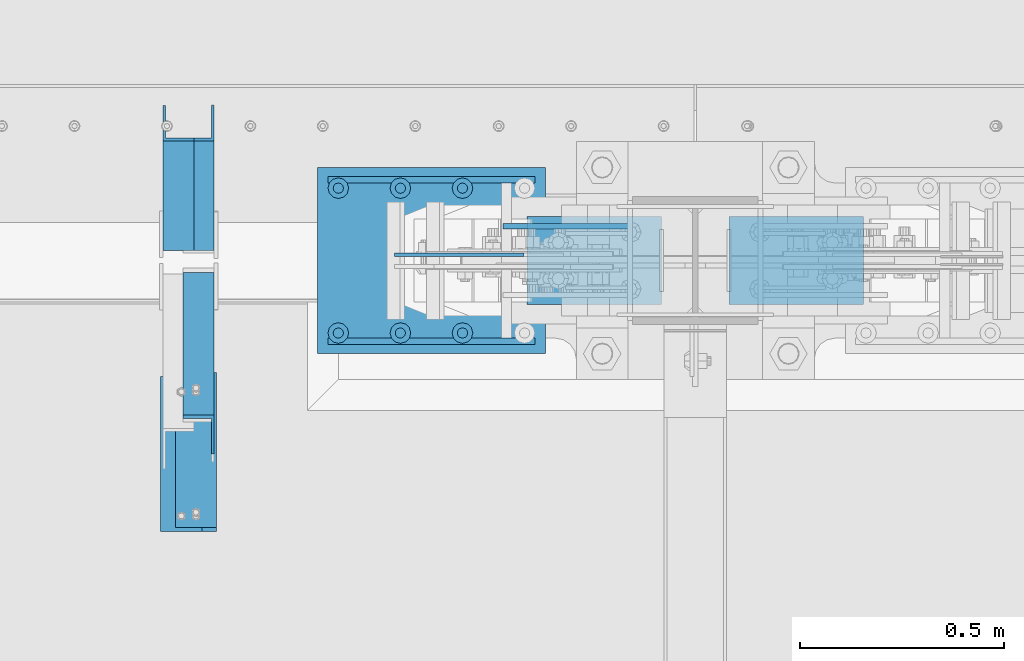
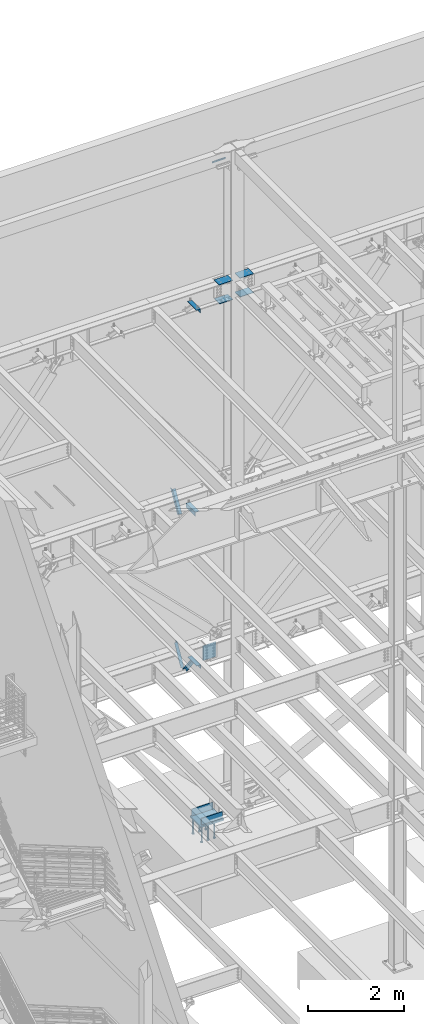
# One storey, part 884 of 1179: 18 beams, 3 members, 11 elements without a shape of their own.
"""IFC2X3 building model written with IfcOpenShell, lengths in millimetres."""

from ifc_helpers import new_model, si_unit, frame, origin_with_axes, place, context, subcontext, project, spatial, faceted_brep, material, type_object, element, aggregate, save


model = new_model("IFC2X3")

# Units and contexts
model_context = context("Model", 3, precision=1e-05, world=origin_with_axes())
body_context = subcontext(model_context, "Body", "Model", "MODEL_VIEW")
ifc_project = project(units=[si_unit("LENGTHUNIT", "METRE", prefix="MILLI"), si_unit("AREAUNIT", "SQUARE_METRE"), si_unit("VOLUMEUNIT", "CUBIC_METRE"), si_unit("MASSUNIT", "GRAM", prefix="KILO"), si_unit("TIMEUNIT", "SECOND"), si_unit("PLANEANGLEUNIT", "RADIAN"), si_unit("SOLIDANGLEUNIT", "STERADIAN"), si_unit("THERMODYNAMICTEMPERATUREUNIT", "DEGREE_CELSIUS"), si_unit("LUMINOUSINTENSITYUNIT", "LUMEN")], contexts=[model_context])

# Site, building, storey
site_placement = place(None, origin_with_axes())
site = spatial("IfcSite", under=ifc_project, at=site_placement, CompositionType="ELEMENT")
building_placement = place(site_placement, origin_with_axes())
building = spatial("IfcBuilding", under=site, at=building_placement, Name="Undefined", CompositionType="ELEMENT")
storey_placement = place(building_placement, origin_with_axes())
storey = spatial("IfcBuildingStorey", under=building, at=storey_placement, Name="Undefined", CompositionType="ELEMENT", Elevation=0.0)

# Assembly, member
assembly_1_placement = place(storey_placement, origin_with_axes())
assembly_1 = element("IfcElementAssembly", 1, at=assembly_1_placement, inside=storey, Name="ANGLE", AssemblyPlace="NOTDEFINED", PredefinedType="RIGID_FRAME")
ifc_material_1 = material(Name="STEEL/A36")
member_type = type_object("IfcMemberType", Name="L3X3X1/4", PredefinedType="NOTDEFINED")
member_1_placement = place(assembly_1_placement, frame((7012.22021260318, 41656.0, 8227.31342088179), z_axis=(0.0, 0.872675718014636, -0.488300206008189), x_axis=(0.0, -0.48830020600819, -0.872675718014636)))
member_1 = element("IfcMember", 2, at=member_1_placement, type_object=member_type, material=ifc_material_1, Name="ANGLE", ObjectType="L3X3X1/4", context=body_context, shape_type="Brep", body=[
    faceted_brep([(266.09845322503, 38.1000000000004, -38.1000000001477), (223.461222774196, 38.1000000000004, 38.0999999997293), (818.212094408347, 38.1000000000004, 38.0999999992346), (818.21209440822, 38.1000000000004, -38.100000000617), (223.461222774196, 31.75, 38.0999999997293), (818.212094408347, 31.75, 38.0999999992346), (262.545350687458, 31.75, -31.7500000001601), (818.212094408227, 31.75, -31.7500000006257), (262.545350687458, -38.1000000000004, -31.7500000001601), (818.212094408227, -38.1000000000004, -31.7500000006257), (266.09845322503, -38.1000000000004, -38.1000000001477), (818.21209440822, -38.1000000000004, -38.100000000617)], [[[0, 1, 2, 3]], [[1, 4, 5, 2]], [[4, 6, 7, 5]], [[6, 8, 9, 7]], [[8, 10, 11, 9]], [[10, 0, 3, 11]], [[5, 7, 9, 11, 3, 2]], [[10, 8, 6, 4, 1, 0]]]),
])
aggregate(assembly_1, [member_1])

assembly_2_placement = place(storey_placement, origin_with_axes())
assembly_2 = element("IfcElementAssembly", 3, at=assembly_2_placement, inside=storey, Name="ANGLE", AssemblyPlace="NOTDEFINED", PredefinedType="RIGID_FRAME")
member_2_placement = place(assembly_2_placement, frame((7061.20000000002, 40722.5022996856, 4156.39103856133), z_axis=(0.0, -0.797785167426298, -0.602941810322185), x_axis=(0.0, 0.602941810322187, -0.797785167426297)))
member_2 = element("IfcMember", 4, at=member_2_placement, type_object=member_type, material=ifc_material_1, Name="ANGLE", ObjectType="L3X3X1/4", context=body_context, shape_type="Brep", body=[
    faceted_brep([(110.776215380578, 38.1000000000004, -38.1000000000058), (53.1865686658894, 38.1000000000004, 38.1000000001659), (690.351875241478, 38.1000000000004, 38.1000000007261), (690.351875241598, 38.1000000000004, -38.0999999994892), (53.1865686658894, 31.75, 38.1000000001659), (690.351875241478, 31.75, 38.1000000007261), (105.977078154352, 31.75, -31.7499999999927), (690.351875241595, 31.75, -31.7499999994689), (105.977078154352, -38.1000000000004, -31.7499999999927), (690.351875241595, -38.1000000000004, -31.7499999994689), (110.776215380578, -38.1000000000004, -38.1000000000058), (690.351875241598, -38.1000000000004, -38.0999999994892)], [[[0, 1, 2, 3]], [[1, 4, 5, 2]], [[4, 6, 7, 5]], [[6, 8, 9, 7]], [[8, 10, 11, 9]], [[10, 0, 3, 11]], [[5, 7, 9, 11, 3, 2]], [[10, 8, 6, 4, 1, 0]]]),
])
aggregate(assembly_2, [member_2])

assembly_3_placement = place(storey_placement, origin_with_axes())
assembly_3 = element("IfcElementAssembly", 5, at=assembly_3_placement, inside=storey, Name="ANGLE", AssemblyPlace="NOTDEFINED", PredefinedType="RIGID_FRAME")
member_3_placement = place(assembly_3_placement, frame((7061.20000000001, 41256.8365589201, 3601.33927004389), z_axis=(0.0, 0.873306509536275, -0.487171161299155), x_axis=(0.0, 0.487171161299156, 0.873306509536275)))
member_3 = element("IfcMember", 6, at=member_3_placement, type_object=member_type, material=ifc_material_1, Name="ANGLE", ObjectType="L3X3X1/4", context=body_context, shape_type="Brep", body=[
    faceted_brep([(0.0, 38.0999999999985, -38.0999999999999), (0.0, 38.0999999999985, 38.0999999999999), (594.661720177039, 38.1000000000004, 38.1000000011991), (552.153801037723, 38.1000000000004, -38.0999999989144), (0.0, 31.75, 38.1000000000004), (594.661720177039, 31.75, 38.1000000011991), (0.0, 31.75, -31.75), (555.696127632669, 31.75, -31.7499999988941), (0.0, -38.0999999999985, -31.75), (555.696127632669, -38.1000000000004, -31.7499999988941), (0.0, -38.0999999999985, -38.0999999999999), (552.153801037723, -38.1000000000004, -38.0999999989144)], [[[0, 1, 2, 3]], [[1, 4, 5, 2]], [[4, 6, 7, 5]], [[6, 8, 9, 7]], [[8, 10, 11, 9]], [[10, 0, 3, 11]], [[5, 7, 9, 11, 3, 2]], [[10, 8, 6, 4, 1, 0]]]),
])
aggregate(assembly_3, [member_3])

# Assembly, beams
assembly_4_placement = place(storey_placement, origin_with_axes())
assembly_4 = element("IfcElementAssembly", 7, at=assembly_4_placement, inside=storey, Name="COLUMN", AssemblyPlace="NOTDEFINED", PredefinedType="RIGID_FRAME")
ifc_material_2 = material(Name="STEEL/A572-GR.50")
beam_type_1 = type_object("IfcBeamType", PredefinedType="NOTDEFINED")
beam_1_placement = place(assembly_4_placement, frame((8198.04673404991, 41198.8000000024, 12646.0249999467), z_axis=(0.0, -1.0, 0.0), x_axis=(-1.0, 0.0, 0.0)))
beam_1 = element("IfcBeam", 8, at=beam_1_placement, type_object=beam_type_1, material=ifc_material_2, Name="PLATE", context=body_context, shape_type="Brep", body=[
    faceted_brep([(0.0, 6.35000000000036, -107.949999999997), (0.0, 6.35000000000036, 107.949999999997), (330.200000043667, 6.35000000000036, 107.949999999997), (330.200000043667, 6.35000000000036, -107.949999999997), (0.0, -6.35000000000036, 107.949999999997), (330.200000043667, -6.35000000000036, 107.949999999997), (0.0, -6.35000000000036, -107.949999999997), (330.200000043667, -6.35000000000036, -107.949999999997)], [[[0, 1, 2, 3]], [[1, 4, 5, 2]], [[4, 6, 7, 5]], [[6, 0, 3, 7]], [[5, 7, 3, 2]], [[6, 4, 1, 0]]]),
])
beam_2_placement = place(assembly_4_placement, frame((8198.04673404293, 41198.8000000024, 13125.4499999468), z_axis=(0.0, -1.0, 0.0), x_axis=(-1.0, 0.0, 0.0)))
beam_2 = element("IfcBeam", 9, at=beam_2_placement, type_object=beam_type_1, material=ifc_material_2, Name="PLATE", context=body_context, shape_type="Brep", body=[
    faceted_brep([(0.0, 6.35000000000036, -107.949999999997), (0.0, 6.35000000000036, 107.949999999997), (330.200000043667, 6.35000000000036, 107.949999999997), (330.200000043667, 6.35000000000036, -107.949999999997), (0.0, -6.35000000000036, 107.949999999997), (330.200000043667, -6.35000000000036, 107.949999999997), (0.0, -6.35000000000036, -107.949999999997), (330.200000043667, -6.35000000000036, -107.949999999997)], [[[0, 1, 2, 3]], [[1, 4, 5, 2]], [[4, 6, 7, 5]], [[6, 0, 3, 7]], [[5, 7, 3, 2]], [[6, 4, 1, 0]]]),
])
beam_3_placement = place(assembly_4_placement, frame((8362.94999935841, 41198.8, 12646.0249999645), z_axis=(0.0, -1.0, 0.0), x_axis=(1.0, 0.0, 0.0)))
beam_3 = element("IfcBeam", 10, at=beam_3_placement, type_object=beam_type_1, material=ifc_material_2, Name="PLATE", context=body_context, shape_type="Brep", body=[
    faceted_brep([(0.0, 6.35000000000036, -107.949999999997), (0.0, 6.35000000000036, 107.949999999997), (330.200000043667, 6.35000000000036, 107.949999999997), (330.200000043667, 6.35000000000036, -107.949999999997), (0.0, -6.35000000000036, 107.949999999997), (330.200000043667, -6.35000000000036, 107.949999999997), (0.0, -6.35000000000036, -107.949999999997), (330.200000043667, -6.35000000000036, -107.949999999997)], [[[0, 1, 2, 3]], [[1, 4, 5, 2]], [[4, 6, 7, 5]], [[6, 0, 3, 7]], [[5, 7, 3, 2]], [[6, 4, 1, 0]]]),
])
beam_4_placement = place(assembly_4_placement, frame((8362.94999937052, 41198.8, 13125.4499999483), z_axis=(0.0, -1.0, 0.0), x_axis=(1.0, 0.0, 0.0)))
beam_4 = element("IfcBeam", 11, at=beam_4_placement, type_object=beam_type_1, material=ifc_material_2, Name="PLATE", context=body_context, shape_type="Brep", body=[
    faceted_brep([(0.0, 6.35000000000036, -107.949999999997), (0.0, 6.35000000000036, 107.949999999997), (330.200000043667, 6.35000000000036, 107.949999999997), (330.200000043667, 6.35000000000036, -107.949999999997), (0.0, -6.35000000000036, 107.949999999997), (330.200000043667, -6.35000000000036, 107.949999999997), (0.0, -6.35000000000036, -107.949999999997), (330.200000043667, -6.35000000000036, -107.949999999997)], [[[0, 1, 2, 3]], [[1, 4, 5, 2]], [[4, 6, 7, 5]], [[6, 0, 3, 7]], [[5, 7, 3, 2]], [[6, 4, 1, 0]]]),
])

# Assembly, beam
assembly_5_placement = place(storey_placement, origin_with_axes())
assembly_5 = element("IfcElementAssembly", 12, at=assembly_5_placement, inside=storey, Name="ANGLE", AssemblyPlace="NOTDEFINED", PredefinedType="RIGID_FRAME")
beam_type_2 = type_object("IfcBeamType", Name="L4X4X1/4", PredefinedType="NOTDEFINED")
beam_5_placement = place(assembly_5_placement, frame((7018.57021260318, 40533.6375, 7962.9), z_axis=(1.0, 0.0, 0.0), x_axis=(0.0, 1.0, 0.0)))
beam_5 = element("IfcBeam", 13, at=beam_5_placement, type_object=beam_type_2, material=ifc_material_1, Name="ANGLE", ObjectType="L4X4X1/4", context=body_context, shape_type="Brep", body=[
    faceted_brep([(1.90993887372315e-11, 50.8000000000002, -50.8000000000002), (1.90993887372315e-11, 50.8000000000002, 50.8000000000002), (381.0, 50.8000000000002, 50.7999999999993), (381.0, 50.8000000000002, -50.7999999999993), (0.0, 44.4500000000007, 50.8000000000002), (381.0, 44.4499999999998, 50.7999999999993), (0.0, 44.4500000000007, -44.4499999999998), (381.0, 44.4499999999998, -44.4500000000007), (0.0, -50.7999999999993, -44.4499999999998), (381.0, -50.8000000000002, -44.4500000000007), (-1.81898940354586e-11, -50.7999999999997, -50.8000000000002), (381.0, -50.8000000000002, -50.7999999999993)], [[[0, 1, 2, 3]], [[1, 4, 5, 2]], [[4, 6, 7, 5]], [[6, 8, 9, 7]], [[8, 10, 11, 9]], [[10, 0, 3, 11]], [[5, 7, 9, 11, 3, 2]], [[10, 8, 6, 4, 1, 0]]]),
])
aggregate(assembly_5, [beam_5])

assembly_6_placement = place(storey_placement, origin_with_axes())
assembly_6 = element("IfcElementAssembly", 14, at=assembly_6_placement, inside=storey, Name="ANGLE", AssemblyPlace="NOTDEFINED", PredefinedType="RIGID_FRAME")
beam_6_placement = place(assembly_6_placement, frame((7054.84999999846, 40914.6375000007, 4051.30000000071), z_axis=(-1.0, 0.0, 0.0), x_axis=(0.0, -1.0, 0.0)))
beam_6 = element("IfcBeam", 15, at=beam_6_placement, type_object=beam_type_2, material=ifc_material_1, Name="ANGLE", ObjectType="L4X4X1/4", context=body_context, shape_type="Brep", body=[
    faceted_brep([(1.90993887372315e-11, 50.8000000000002, -50.8000000000002), (1.90993887372315e-11, 50.8000000000002, 50.8000000000002), (381.0, 50.8000000000002, 50.7999999999993), (381.0, 50.8000000000002, -50.7999999999993), (0.0, 44.4500000000007, 50.8000000000002), (381.0, 44.4499999999998, 50.7999999999993), (0.0, 44.4500000000007, -44.4499999999998), (381.0, 44.4499999999998, -44.4500000000007), (0.0, -50.7999999999993, -44.4499999999998), (381.0, -50.8000000000002, -44.4500000000007), (-1.81898940354586e-11, -50.7999999999997, -50.8000000000002), (381.0, -50.8000000000002, -50.7999999999993)], [[[0, 1, 2, 3]], [[1, 4, 5, 2]], [[4, 6, 7, 5]], [[6, 8, 9, 7]], [[8, 10, 11, 9]], [[10, 0, 3, 11]], [[5, 7, 9, 11, 3, 2]], [[10, 8, 6, 4, 1, 0]]]),
])
aggregate(assembly_6, [beam_6])

assembly_7_placement = place(storey_placement, origin_with_axes())
assembly_7 = element("IfcElementAssembly", 16, at=assembly_7_placement, inside=storey, Name="ANGLE", AssemblyPlace="NOTDEFINED", PredefinedType="RIGID_FRAME")
beam_7_placement = place(assembly_7_placement, frame((7054.84999999795, 40924.1624999532, 13068.3), z_axis=(-1.0, 0.0, 0.0), x_axis=(0.0, -1.0, 0.0)))
beam_7 = element("IfcBeam", 17, at=beam_7_placement, type_object=beam_type_2, material=ifc_material_1, Name="ANGLE", ObjectType="L4X4X1/4", context=body_context, shape_type="Brep", body=[
    faceted_brep([(1.90993887372315e-11, 50.8000000000002, -50.8000000000002), (1.90993887372315e-11, 50.8000000000002, 50.8000000000002), (381.0, 50.8000000000002, 50.7999999999993), (381.0, 50.8000000000002, -50.7999999999993), (0.0, 44.4500000000007, 50.8000000000002), (381.0, 44.4499999999998, 50.7999999999993), (0.0, 44.4500000000007, -44.4499999999998), (381.0, 44.4499999999998, -44.4500000000007), (0.0, -50.7999999999993, -44.4499999999998), (381.0, -50.8000000000002, -44.4500000000007), (-1.81898940354586e-11, -50.7999999999997, -50.8000000000002), (381.0, -50.8000000000002, -50.7999999999993)], [[[0, 1, 2, 3]], [[1, 4, 5, 2]], [[4, 6, 7, 5]], [[6, 8, 9, 7]], [[8, 10, 11, 9]], [[10, 0, 3, 11]], [[5, 7, 9, 11, 3, 2]], [[10, 8, 6, 4, 1, 0]]]),
])
aggregate(assembly_7, [beam_7])

# Beam
beam_type_3 = type_object("IfcBeamType", PredefinedType="NOTDEFINED")
beam_8_placement = place(assembly_4_placement, frame((7808.9125, 41282.9375, 16141.7), z_axis=(0.0, 0.0, 1.0), x_axis=(1.0, 0.0, 0.0)))
beam_8 = element("IfcBeam", 18, at=beam_8_placement, type_object=beam_type_3, material=ifc_material_1, Name="PLATE", context=body_context, shape_type="Brep", body=[
    faceted_brep([(0.0, 6.34999999999854, -19.0499999999993), (0.0, 6.35000000000036, 19.0499999999993), (317.5, 6.34999999999854, 19.0499999999993), (317.5, 6.34999999999854, -19.0499999999993), (0.0, -6.35000000000036, 19.0499999999993), (317.5, -6.34999999999854, 19.0499999999993), (0.0, -6.34999999999854, -19.0499999999993), (317.5, -6.34999999999854, -19.0499999999993)], [[[0, 1, 2, 3]], [[1, 4, 5, 2]], [[4, 6, 7, 5]], [[6, 0, 3, 7]], [[5, 7, 3, 2]], [[6, 4, 1, 0]]]),
])

aggregate(assembly_4, [beam_1, beam_2, beam_3, beam_4, beam_8])

# Assembly, beam
assembly_8_placement = place(storey_placement, origin_with_axes())
assembly_8 = element("IfcElementAssembly", 19, at=assembly_8_placement, inside=storey, Name="PLATE", AssemblyPlace="NOTDEFINED", PredefinedType="RIGID_FRAME")
beam_type_4 = type_object("IfcBeamType", PredefinedType="NOTDEFINED")
beam_9_placement = place(assembly_8_placement, frame((7859.8869148553, 41213.0872136118, 3827.46249389647), z_axis=(0.0, 0.0, -1.0), x_axis=(-1.0, 0.0, 0.0)))
beam_9 = element("IfcBeam", 20, at=beam_9_placement, type_object=beam_type_4, material=ifc_material_2, Name="PLATE", context=body_context, shape_type="Brep", body=[
    faceted_brep([(0.0, 4.76249999999709, -190.5), (0.0, 4.76249999999709, 190.5), (317.499999999995, 4.76250000000073, 190.500000000051), (317.500000000042, 4.76250000000073, -190.499999999973), (0.0, -4.76249999999709, 190.5), (317.499999999995, -4.76250000000073, 190.500000000051), (0.0, -4.76249999999709, -190.5), (317.500000000042, -4.76250000000073, -190.499999999973)], [[[0, 1, 2, 3]], [[1, 4, 5, 2]], [[4, 6, 7, 5]], [[6, 0, 3, 7]], [[5, 7, 3, 2]], [[6, 4, 1, 0]]]),
])
aggregate(assembly_8, [beam_9])

assembly_9_placement = place(storey_placement, origin_with_axes())
assembly_9 = element("IfcElementAssembly", 21, at=assembly_9_placement, inside=storey, Name="PLATE", AssemblyPlace="NOTDEFINED", PredefinedType="RIGID_FRAME")
beam_type_5 = type_object("IfcBeamType", PredefinedType="NOTDEFINED")
beam_10_placement = place(assembly_9_placement, frame((7378.70000000002, 41397.2375015263, -266.7), z_axis=(0.0, 0.0, 1.0), x_axis=(1.0, 0.0, 0.0)))
beam_10 = element("IfcBeam", 22, at=beam_10_placement, type_object=beam_type_5, material=ifc_material_2, Name="PLATE", context=body_context, shape_type="Brep", body=[
    faceted_brep([(0.0, -7.9375, -88.9), (0.0, 7.9375, -73.025), (508.0, 7.9375, -73.025), (508.0, -7.9375, -88.9), (0.0, 7.9375, 88.9), (508.0, 7.9375, 88.9), (0.0, -7.9375, 88.9), (508.0, -7.9375, 88.9)], [[[0, 1, 2, 3]], [[4, 5, 2, 1]], [[4, 6, 7, 5]], [[6, 0, 3, 7]], [[5, 7, 3, 2]], [[6, 4, 1, 0]]]),
])
aggregate(assembly_9, [beam_10])

assembly_10_placement = place(storey_placement, origin_with_axes())
assembly_10 = element("IfcElementAssembly", 23, at=assembly_10_placement, inside=storey, Name="PLATE", AssemblyPlace="NOTDEFINED", PredefinedType="RIGID_FRAME")
beam_11_placement = place(assembly_10_placement, frame((7378.70000000002, 41000.3624984737, -266.7), z_axis=(0.0, 0.0, 1.0), x_axis=(1.0, 0.0, 0.0)))
beam_11 = element("IfcBeam", 24, at=beam_11_placement, type_object=beam_type_5, material=ifc_material_2, Name="PLATE", context=body_context, shape_type="Brep", body=[
    faceted_brep([(508.0, 7.9375, -88.9), (508.0, -7.9375, -73.025), (0.0, -7.9375, -73.025), (0.0, 7.9375, -88.9), (0.0, 7.9375, 88.9), (508.0, 7.9375, 88.9), (0.0, -7.9375, 88.9), (508.0, -7.9375, 88.9)], [[[0, 1, 2, 3]], [[3, 4, 5, 0]], [[4, 6, 7, 5]], [[7, 6, 2, 1]], [[5, 7, 1, 0]], [[6, 4, 3, 2]]]),
])
aggregate(assembly_10, [beam_11])

# Assembly, beams
assembly_11_placement = place(storey_placement, origin_with_axes())
assembly_11 = element("IfcElementAssembly", 25, at=assembly_11_placement, inside=storey, Name="EMBED_PLATE", AssemblyPlace="NOTDEFINED", PredefinedType="RIGID_FRAME")
ifc_material_3 = material(Name="STEEL/A108")
beam_type_6 = type_object("IfcBeamType", Name="STUD_1-DIA", PredefinedType="NOTDEFINED")
beam_12_placement = place(assembly_11_placement, frame((7708.90000000002, 41376.6, -393.7), z_axis=(1.0, 0.0, 0.0), x_axis=(0.0, 0.0, -1.0)))
beam_12 = element("IfcBeam", 26, at=beam_12_placement, type_object=beam_type_6, material=ifc_material_3, Name="STUD", ObjectType="STUD_1-DIA", context=body_context, shape_type="Brep", body=[
    faceted_brep([(0.0, -12.7, 0.0), (0.0, -11.0, -6.34999990463257), (382.016, -11.0, -6.34999990463257), (382.016, -12.6999998092651, 0.0), (0.0, -6.34999990463257, -11.0), (382.016, -6.34999990463257, -11.0), (0.0, 0.0, -12.6999998092651), (382.016, 0.0, -12.6999998092651), (0.0, 6.34999990463257, -11.0), (382.016, 6.34999990463257, -11.0), (0.0, 11.0, -6.34999990463257), (382.016, 11.0, -6.34999990463257), (0.0, 12.7, 0.0), (382.016, 12.6999998092651, 0.0), (0.0, 11.0, 6.34999990463257), (382.016, 11.0, 6.34999990463257), (0.0, 6.34999990463257, 11.0), (382.016, 6.34999990463257, 11.0), (0.0, 0.0, 12.6999998092651), (382.016, 0.0, 12.6999998092651), (0.0, -6.34999990463257, 11.0), (382.016, -6.34999990463257, 11.0), (0.0, -11.0, 6.34999990463257), (382.016, -11.0, 6.34999990463257), (386.08, -22.0, -12.6999998092651), (386.08, -25.3999996185303, 0.0), (386.08, -12.6999998092651, -22.0), (386.08, 0.0, -25.3999996185303), (386.08, 12.6999998092651, -22.0), (386.08, 22.0, -12.6999998092651), (386.08, 25.3999996185303, 0.0), (386.08, 22.0, 12.6999998092651), (386.08, 12.6999998092651, 22.0), (386.08, 0.0, 25.3999996185303), (386.08, -12.6999998092651, 22.0), (386.08, -22.0, 12.6999998092651), (406.4, -22.0, -12.6999998092651), (406.4, -25.3999996185303, 0.0), (406.4, -12.6999998092651, -22.0), (406.4, 0.0, -25.3999996185303), (406.4, 12.6999998092651, -22.0), (406.4, 22.0, -12.6999998092651), (406.4, 25.3999996185303, 0.0), (406.4, 22.0, 12.6999998092651), (406.4, 12.6999998092651, 22.0), (406.4, 0.0, 25.3999996185303), (406.4, -12.6999998092651, 22.0), (406.4, -22.0, 12.6999998092651)], [[[0, 1, 2, 3]], [[1, 4, 5, 2]], [[4, 6, 7, 5]], [[6, 8, 9, 7]], [[8, 10, 11, 9]], [[10, 12, 13, 11]], [[12, 14, 15, 13]], [[14, 16, 17, 15]], [[16, 18, 19, 17]], [[18, 20, 21, 19]], [[20, 22, 23, 21]], [[22, 0, 3, 23]], [[22, 20, 18, 16, 14, 12, 10, 8, 6, 4, 1, 0]], [[3, 2, 24, 25]], [[2, 5, 26, 24]], [[5, 7, 27, 26]], [[7, 9, 28, 27]], [[9, 11, 29, 28]], [[11, 13, 30, 29]], [[13, 15, 31, 30]], [[15, 17, 32, 31]], [[17, 19, 33, 32]], [[19, 21, 34, 33]], [[21, 23, 35, 34]], [[23, 3, 25, 35]], [[25, 24, 36, 37]], [[24, 26, 38, 36]], [[26, 27, 39, 38]], [[27, 28, 40, 39]], [[28, 29, 41, 40]], [[29, 30, 42, 41]], [[30, 31, 43, 42]], [[31, 32, 44, 43]], [[32, 33, 45, 44]], [[33, 34, 46, 45]], [[34, 35, 47, 46]], [[35, 25, 37, 47]], [[38, 39, 40, 41, 42, 43, 44, 45, 46, 47, 37, 36]]]),
])
beam_13_placement = place(assembly_11_placement, frame((7556.50000000002, 41376.6, -393.7), z_axis=(1.0, 0.0, 0.0), x_axis=(0.0, 0.0, -1.0)))
beam_13 = element("IfcBeam", 27, at=beam_13_placement, type_object=beam_type_6, material=ifc_material_3, Name="STUD", ObjectType="STUD_1-DIA", context=body_context, shape_type="Brep", body=[
    faceted_brep([(0.0, -12.7, 0.0), (0.0, -11.0, -6.34999990463257), (382.016, -11.0, -6.34999990463257), (382.016, -12.6999998092651, 0.0), (0.0, -6.34999990463257, -11.0), (382.016, -6.34999990463257, -11.0), (0.0, 0.0, -12.6999998092651), (382.016, 0.0, -12.6999998092651), (0.0, 6.34999990463257, -11.0), (382.016, 6.34999990463257, -11.0), (0.0, 11.0, -6.34999990463257), (382.016, 11.0, -6.34999990463257), (0.0, 12.7, 0.0), (382.016, 12.6999998092651, 0.0), (0.0, 11.0, 6.34999990463257), (382.016, 11.0, 6.34999990463257), (0.0, 6.34999990463257, 11.0), (382.016, 6.34999990463257, 11.0), (0.0, 0.0, 12.6999998092651), (382.016, 0.0, 12.6999998092651), (0.0, -6.34999990463257, 11.0), (382.016, -6.34999990463257, 11.0), (0.0, -11.0, 6.34999990463257), (382.016, -11.0, 6.34999990463257), (386.08, -22.0, -12.6999998092651), (386.08, -25.3999996185303, 0.0), (386.08, -12.6999998092651, -22.0), (386.08, 0.0, -25.3999996185303), (386.08, 12.6999998092651, -22.0), (386.08, 22.0, -12.6999998092651), (386.08, 25.3999996185303, 0.0), (386.08, 22.0, 12.6999998092651), (386.08, 12.6999998092651, 22.0), (386.08, 0.0, 25.3999996185303), (386.08, -12.6999998092651, 22.0), (386.08, -22.0, 12.6999998092651), (406.4, -22.0, -12.6999998092651), (406.4, -25.3999996185303, 0.0), (406.4, -12.6999998092651, -22.0), (406.4, 0.0, -25.3999996185303), (406.4, 12.6999998092651, -22.0), (406.4, 22.0, -12.6999998092651), (406.4, 25.3999996185303, 0.0), (406.4, 22.0, 12.6999998092651), (406.4, 12.6999998092651, 22.0), (406.4, 0.0, 25.3999996185303), (406.4, -12.6999998092651, 22.0), (406.4, -22.0, 12.6999998092651)], [[[0, 1, 2, 3]], [[1, 4, 5, 2]], [[4, 6, 7, 5]], [[6, 8, 9, 7]], [[8, 10, 11, 9]], [[10, 12, 13, 11]], [[12, 14, 15, 13]], [[14, 16, 17, 15]], [[16, 18, 19, 17]], [[18, 20, 21, 19]], [[20, 22, 23, 21]], [[22, 0, 3, 23]], [[22, 20, 18, 16, 14, 12, 10, 8, 6, 4, 1, 0]], [[3, 2, 24, 25]], [[2, 5, 26, 24]], [[5, 7, 27, 26]], [[7, 9, 28, 27]], [[9, 11, 29, 28]], [[11, 13, 30, 29]], [[13, 15, 31, 30]], [[15, 17, 32, 31]], [[17, 19, 33, 32]], [[19, 21, 34, 33]], [[21, 23, 35, 34]], [[23, 3, 25, 35]], [[25, 24, 36, 37]], [[24, 26, 38, 36]], [[26, 27, 39, 38]], [[27, 28, 40, 39]], [[28, 29, 41, 40]], [[29, 30, 42, 41]], [[30, 31, 43, 42]], [[31, 32, 44, 43]], [[32, 33, 45, 44]], [[33, 34, 46, 45]], [[34, 35, 47, 46]], [[35, 25, 37, 47]], [[38, 39, 40, 41, 42, 43, 44, 45, 46, 47, 37, 36]]]),
])
beam_14_placement = place(assembly_11_placement, frame((7404.10000000002, 41376.6, -393.7), z_axis=(1.0, 0.0, 0.0), x_axis=(0.0, 0.0, -1.0)))
beam_14 = element("IfcBeam", 28, at=beam_14_placement, type_object=beam_type_6, material=ifc_material_3, Name="STUD", ObjectType="STUD_1-DIA", context=body_context, shape_type="Brep", body=[
    faceted_brep([(0.0, -12.7, 0.0), (0.0, -11.0, -6.34999990463257), (382.016, -11.0, -6.34999990463257), (382.016, -12.6999998092651, 0.0), (0.0, -6.34999990463257, -11.0), (382.016, -6.34999990463257, -11.0), (0.0, 0.0, -12.6999998092651), (382.016, 0.0, -12.6999998092651), (0.0, 6.34999990463257, -11.0), (382.016, 6.34999990463257, -11.0), (0.0, 11.0, -6.34999990463257), (382.016, 11.0, -6.34999990463257), (0.0, 12.7, 0.0), (382.016, 12.6999998092651, 0.0), (0.0, 11.0, 6.34999990463257), (382.016, 11.0, 6.34999990463257), (0.0, 6.34999990463257, 11.0), (382.016, 6.34999990463257, 11.0), (0.0, 0.0, 12.6999998092651), (382.016, 0.0, 12.6999998092651), (0.0, -6.34999990463257, 11.0), (382.016, -6.34999990463257, 11.0), (0.0, -11.0, 6.34999990463257), (382.016, -11.0, 6.34999990463257), (386.08, -22.0, -12.6999998092651), (386.08, -25.3999996185303, 0.0), (386.08, -12.6999998092651, -22.0), (386.08, 0.0, -25.3999996185303), (386.08, 12.6999998092651, -22.0), (386.08, 22.0, -12.6999998092651), (386.08, 25.3999996185303, 0.0), (386.08, 22.0, 12.6999998092651), (386.08, 12.6999998092651, 22.0), (386.08, 0.0, 25.3999996185303), (386.08, -12.6999998092651, 22.0), (386.08, -22.0, 12.6999998092651), (406.4, -22.0, -12.6999998092651), (406.4, -25.3999996185303, 0.0), (406.4, -12.6999998092651, -22.0), (406.4, 0.0, -25.3999996185303), (406.4, 12.6999998092651, -22.0), (406.4, 22.0, -12.6999998092651), (406.4, 25.3999996185303, 0.0), (406.4, 22.0, 12.6999998092651), (406.4, 12.6999998092651, 22.0), (406.4, 0.0, 25.3999996185303), (406.4, -12.6999998092651, 22.0), (406.4, -22.0, 12.6999998092651)], [[[0, 1, 2, 3]], [[1, 4, 5, 2]], [[4, 6, 7, 5]], [[6, 8, 9, 7]], [[8, 10, 11, 9]], [[10, 12, 13, 11]], [[12, 14, 15, 13]], [[14, 16, 17, 15]], [[16, 18, 19, 17]], [[18, 20, 21, 19]], [[20, 22, 23, 21]], [[22, 0, 3, 23]], [[22, 20, 18, 16, 14, 12, 10, 8, 6, 4, 1, 0]], [[3, 2, 24, 25]], [[2, 5, 26, 24]], [[5, 7, 27, 26]], [[7, 9, 28, 27]], [[9, 11, 29, 28]], [[11, 13, 30, 29]], [[13, 15, 31, 30]], [[15, 17, 32, 31]], [[17, 19, 33, 32]], [[19, 21, 34, 33]], [[21, 23, 35, 34]], [[23, 3, 25, 35]], [[25, 24, 36, 37]], [[24, 26, 38, 36]], [[26, 27, 39, 38]], [[27, 28, 40, 39]], [[28, 29, 41, 40]], [[29, 30, 42, 41]], [[30, 31, 43, 42]], [[31, 32, 44, 43]], [[32, 33, 45, 44]], [[33, 34, 46, 45]], [[34, 35, 47, 46]], [[35, 25, 37, 47]], [[38, 39, 40, 41, 42, 43, 44, 45, 46, 47, 37, 36]]]),
])
beam_15_placement = place(assembly_11_placement, frame((7708.90000000002, 41021.0, -393.7), z_axis=(1.0, 0.0, 0.0), x_axis=(0.0, 0.0, -1.0)))
beam_15 = element("IfcBeam", 29, at=beam_15_placement, type_object=beam_type_6, material=ifc_material_3, Name="STUD", ObjectType="STUD_1-DIA", context=body_context, shape_type="Brep", body=[
    faceted_brep([(0.0, -12.7, 0.0), (0.0, -11.0, -6.34999990463257), (382.016, -11.0, -6.34999990463257), (382.016, -12.6999998092651, 0.0), (0.0, -6.34999990463257, -11.0), (382.016, -6.34999990463257, -11.0), (0.0, 0.0, -12.6999998092651), (382.016, 0.0, -12.6999998092651), (0.0, 6.34999990463257, -11.0), (382.016, 6.34999990463257, -11.0), (0.0, 11.0, -6.34999990463257), (382.016, 11.0, -6.34999990463257), (0.0, 12.7, 0.0), (382.016, 12.6999998092651, 0.0), (0.0, 11.0, 6.34999990463257), (382.016, 11.0, 6.34999990463257), (0.0, 6.34999990463257, 11.0), (382.016, 6.34999990463257, 11.0), (0.0, 0.0, 12.6999998092651), (382.016, 0.0, 12.6999998092651), (0.0, -6.34999990463257, 11.0), (382.016, -6.34999990463257, 11.0), (0.0, -11.0, 6.34999990463257), (382.016, -11.0, 6.34999990463257), (386.08, -22.0, -12.6999998092651), (386.08, -25.3999996185303, 0.0), (386.08, -12.6999998092651, -22.0), (386.08, 0.0, -25.3999996185303), (386.08, 12.6999998092651, -22.0), (386.08, 22.0, -12.6999998092651), (386.08, 25.3999996185303, 0.0), (386.08, 22.0, 12.6999998092651), (386.08, 12.6999998092651, 22.0), (386.08, 0.0, 25.3999996185303), (386.08, -12.6999998092651, 22.0), (386.08, -22.0, 12.6999998092651), (406.4, -22.0, -12.6999998092651), (406.4, -25.3999996185303, 0.0), (406.4, -12.6999998092651, -22.0), (406.4, 0.0, -25.3999996185303), (406.4, 12.6999998092651, -22.0), (406.4, 22.0, -12.6999998092651), (406.4, 25.3999996185303, 0.0), (406.4, 22.0, 12.6999998092651), (406.4, 12.6999998092651, 22.0), (406.4, 0.0, 25.3999996185303), (406.4, -12.6999998092651, 22.0), (406.4, -22.0, 12.6999998092651)], [[[0, 1, 2, 3]], [[1, 4, 5, 2]], [[4, 6, 7, 5]], [[6, 8, 9, 7]], [[8, 10, 11, 9]], [[10, 12, 13, 11]], [[12, 14, 15, 13]], [[14, 16, 17, 15]], [[16, 18, 19, 17]], [[18, 20, 21, 19]], [[20, 22, 23, 21]], [[22, 0, 3, 23]], [[22, 20, 18, 16, 14, 12, 10, 8, 6, 4, 1, 0]], [[3, 2, 24, 25]], [[2, 5, 26, 24]], [[5, 7, 27, 26]], [[7, 9, 28, 27]], [[9, 11, 29, 28]], [[11, 13, 30, 29]], [[13, 15, 31, 30]], [[15, 17, 32, 31]], [[17, 19, 33, 32]], [[19, 21, 34, 33]], [[21, 23, 35, 34]], [[23, 3, 25, 35]], [[25, 24, 36, 37]], [[24, 26, 38, 36]], [[26, 27, 39, 38]], [[27, 28, 40, 39]], [[28, 29, 41, 40]], [[29, 30, 42, 41]], [[30, 31, 43, 42]], [[31, 32, 44, 43]], [[32, 33, 45, 44]], [[33, 34, 46, 45]], [[34, 35, 47, 46]], [[35, 25, 37, 47]], [[38, 39, 40, 41, 42, 43, 44, 45, 46, 47, 37, 36]]]),
])
beam_16_placement = place(assembly_11_placement, frame((7556.50000000002, 41021.0, -393.7), z_axis=(1.0, 0.0, 0.0), x_axis=(0.0, 0.0, -1.0)))
beam_16 = element("IfcBeam", 30, at=beam_16_placement, type_object=beam_type_6, material=ifc_material_3, Name="STUD", ObjectType="STUD_1-DIA", context=body_context, shape_type="Brep", body=[
    faceted_brep([(0.0, -12.7, 0.0), (0.0, -11.0, -6.34999990463257), (382.016, -11.0, -6.34999990463257), (382.016, -12.6999998092651, 0.0), (0.0, -6.34999990463257, -11.0), (382.016, -6.34999990463257, -11.0), (0.0, 0.0, -12.6999998092651), (382.016, 0.0, -12.6999998092651), (0.0, 6.34999990463257, -11.0), (382.016, 6.34999990463257, -11.0), (0.0, 11.0, -6.34999990463257), (382.016, 11.0, -6.34999990463257), (0.0, 12.7, 0.0), (382.016, 12.6999998092651, 0.0), (0.0, 11.0, 6.34999990463257), (382.016, 11.0, 6.34999990463257), (0.0, 6.34999990463257, 11.0), (382.016, 6.34999990463257, 11.0), (0.0, 0.0, 12.6999998092651), (382.016, 0.0, 12.6999998092651), (0.0, -6.34999990463257, 11.0), (382.016, -6.34999990463257, 11.0), (0.0, -11.0, 6.34999990463257), (382.016, -11.0, 6.34999990463257), (386.08, -22.0, -12.6999998092651), (386.08, -25.3999996185303, 0.0), (386.08, -12.6999998092651, -22.0), (386.08, 0.0, -25.3999996185303), (386.08, 12.6999998092651, -22.0), (386.08, 22.0, -12.6999998092651), (386.08, 25.3999996185303, 0.0), (386.08, 22.0, 12.6999998092651), (386.08, 12.6999998092651, 22.0), (386.08, 0.0, 25.3999996185303), (386.08, -12.6999998092651, 22.0), (386.08, -22.0, 12.6999998092651), (406.4, -22.0, -12.6999998092651), (406.4, -25.3999996185303, 0.0), (406.4, -12.6999998092651, -22.0), (406.4, 0.0, -25.3999996185303), (406.4, 12.6999998092651, -22.0), (406.4, 22.0, -12.6999998092651), (406.4, 25.3999996185303, 0.0), (406.4, 22.0, 12.6999998092651), (406.4, 12.6999998092651, 22.0), (406.4, 0.0, 25.3999996185303), (406.4, -12.6999998092651, 22.0), (406.4, -22.0, 12.6999998092651)], [[[0, 1, 2, 3]], [[1, 4, 5, 2]], [[4, 6, 7, 5]], [[6, 8, 9, 7]], [[8, 10, 11, 9]], [[10, 12, 13, 11]], [[12, 14, 15, 13]], [[14, 16, 17, 15]], [[16, 18, 19, 17]], [[18, 20, 21, 19]], [[20, 22, 23, 21]], [[22, 0, 3, 23]], [[22, 20, 18, 16, 14, 12, 10, 8, 6, 4, 1, 0]], [[3, 2, 24, 25]], [[2, 5, 26, 24]], [[5, 7, 27, 26]], [[7, 9, 28, 27]], [[9, 11, 29, 28]], [[11, 13, 30, 29]], [[13, 15, 31, 30]], [[15, 17, 32, 31]], [[17, 19, 33, 32]], [[19, 21, 34, 33]], [[21, 23, 35, 34]], [[23, 3, 25, 35]], [[25, 24, 36, 37]], [[24, 26, 38, 36]], [[26, 27, 39, 38]], [[27, 28, 40, 39]], [[28, 29, 41, 40]], [[29, 30, 42, 41]], [[30, 31, 43, 42]], [[31, 32, 44, 43]], [[32, 33, 45, 44]], [[33, 34, 46, 45]], [[34, 35, 47, 46]], [[35, 25, 37, 47]], [[38, 39, 40, 41, 42, 43, 44, 45, 46, 47, 37, 36]]]),
])
beam_17_placement = place(assembly_11_placement, frame((7404.10000000002, 41021.0, -393.7), z_axis=(1.0, 0.0, 0.0), x_axis=(0.0, 0.0, -1.0)))
beam_17 = element("IfcBeam", 31, at=beam_17_placement, type_object=beam_type_6, material=ifc_material_3, Name="STUD", ObjectType="STUD_1-DIA", context=body_context, shape_type="Brep", body=[
    faceted_brep([(0.0, -12.7, 0.0), (0.0, -11.0, -6.34999990463257), (382.016, -11.0, -6.34999990463257), (382.016, -12.6999998092651, 0.0), (0.0, -6.34999990463257, -11.0), (382.016, -6.34999990463257, -11.0), (0.0, 0.0, -12.6999998092651), (382.016, 0.0, -12.6999998092651), (0.0, 6.34999990463257, -11.0), (382.016, 6.34999990463257, -11.0), (0.0, 11.0, -6.34999990463257), (382.016, 11.0, -6.34999990463257), (0.0, 12.7, 0.0), (382.016, 12.6999998092651, 0.0), (0.0, 11.0, 6.34999990463257), (382.016, 11.0, 6.34999990463257), (0.0, 6.34999990463257, 11.0), (382.016, 6.34999990463257, 11.0), (0.0, 0.0, 12.6999998092651), (382.016, 0.0, 12.6999998092651), (0.0, -6.34999990463257, 11.0), (382.016, -6.34999990463257, 11.0), (0.0, -11.0, 6.34999990463257), (382.016, -11.0, 6.34999990463257), (386.08, -22.0, -12.6999998092651), (386.08, -25.3999996185303, 0.0), (386.08, -12.6999998092651, -22.0), (386.08, 0.0, -25.3999996185303), (386.08, 12.6999998092651, -22.0), (386.08, 22.0, -12.6999998092651), (386.08, 25.3999996185303, 0.0), (386.08, 22.0, 12.6999998092651), (386.08, 12.6999998092651, 22.0), (386.08, 0.0, 25.3999996185303), (386.08, -12.6999998092651, 22.0), (386.08, -22.0, 12.6999998092651), (406.4, -22.0, -12.6999998092651), (406.4, -25.3999996185303, 0.0), (406.4, -12.6999998092651, -22.0), (406.4, 0.0, -25.3999996185303), (406.4, 12.6999998092651, -22.0), (406.4, 22.0, -12.6999998092651), (406.4, 25.3999996185303, 0.0), (406.4, 22.0, 12.6999998092651), (406.4, 12.6999998092651, 22.0), (406.4, 0.0, 25.3999996185303), (406.4, -12.6999998092651, 22.0), (406.4, -22.0, 12.6999998092651)], [[[0, 1, 2, 3]], [[1, 4, 5, 2]], [[4, 6, 7, 5]], [[6, 8, 9, 7]], [[8, 10, 11, 9]], [[10, 12, 13, 11]], [[12, 14, 15, 13]], [[14, 16, 17, 15]], [[16, 18, 19, 17]], [[18, 20, 21, 19]], [[20, 22, 23, 21]], [[22, 0, 3, 23]], [[22, 20, 18, 16, 14, 12, 10, 8, 6, 4, 1, 0]], [[3, 2, 24, 25]], [[2, 5, 26, 24]], [[5, 7, 27, 26]], [[7, 9, 28, 27]], [[9, 11, 29, 28]], [[11, 13, 30, 29]], [[13, 15, 31, 30]], [[15, 17, 32, 31]], [[17, 19, 33, 32]], [[19, 21, 34, 33]], [[21, 23, 35, 34]], [[23, 3, 25, 35]], [[25, 24, 36, 37]], [[24, 26, 38, 36]], [[26, 27, 39, 38]], [[27, 28, 40, 39]], [[28, 29, 41, 40]], [[29, 30, 42, 41]], [[30, 31, 43, 42]], [[31, 32, 44, 43]], [[32, 33, 45, 44]], [[33, 34, 46, 45]], [[34, 35, 47, 46]], [[35, 25, 37, 47]], [[38, 39, 40, 41, 42, 43, 44, 45, 46, 47, 37, 36]]]),
])
beam_type_7 = type_object("IfcBeamType", PredefinedType="NOTDEFINED")
beam_18_placement = place(assembly_11_placement, frame((7353.30000000002, 41198.8, -374.65), z_axis=(0.0, 1.0, 0.0), x_axis=(1.0, 0.0, 0.0)))
beam_18 = element("IfcBeam", 32, at=beam_18_placement, type_object=beam_type_7, material=ifc_material_2, Name="EMBED_PLATE", context=body_context, shape_type="Brep", body=[
    faceted_brep([(0.0, 19.05, -228.6), (0.0, 19.05, 228.6), (558.800000000003, 19.05, 228.599999999999), (558.800000000003, 19.05, -228.599999999999), (0.0, -19.05, 228.6), (558.800000000003, -19.05, 228.599999999999), (0.0, -19.05, -228.6), (558.800000000003, -19.05, -228.599999999999)], [[[0, 1, 2, 3]], [[1, 4, 5, 2]], [[4, 6, 7, 5]], [[6, 0, 3, 7]], [[5, 7, 3, 2]], [[6, 4, 1, 0]]]),
])
aggregate(assembly_11, [beam_12, beam_13, beam_14, beam_15, beam_16, beam_17, beam_18])

save(model, "model.ifc")
